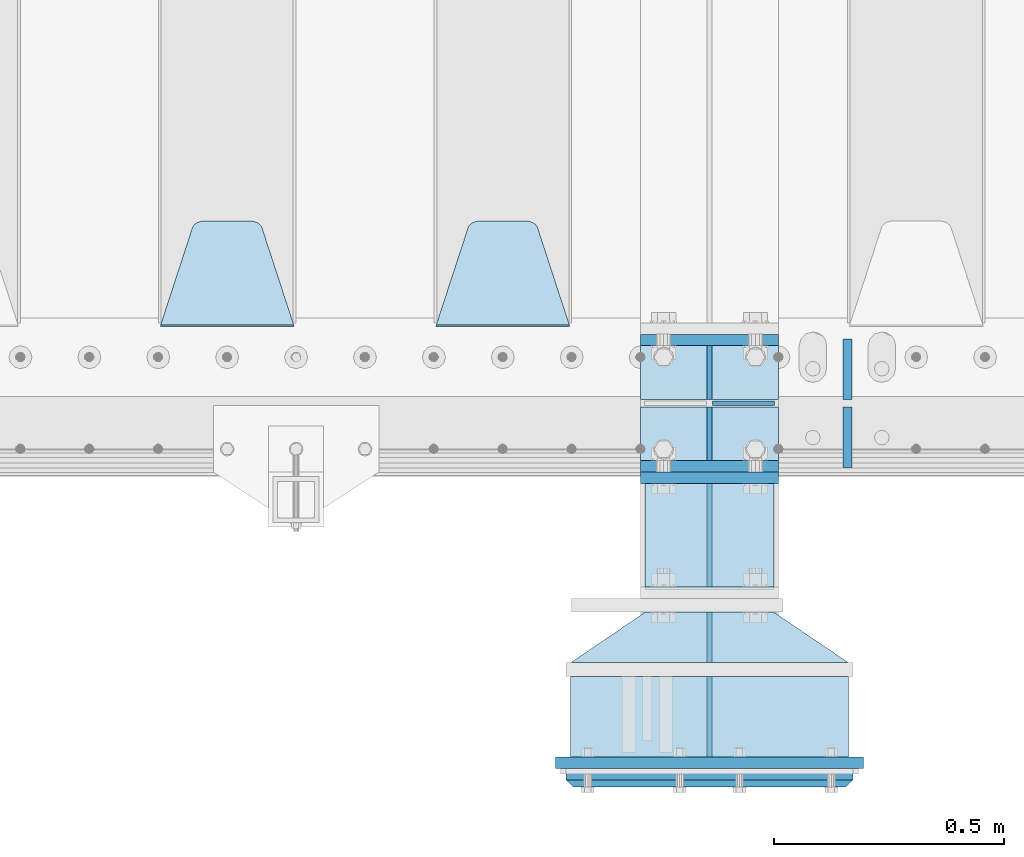
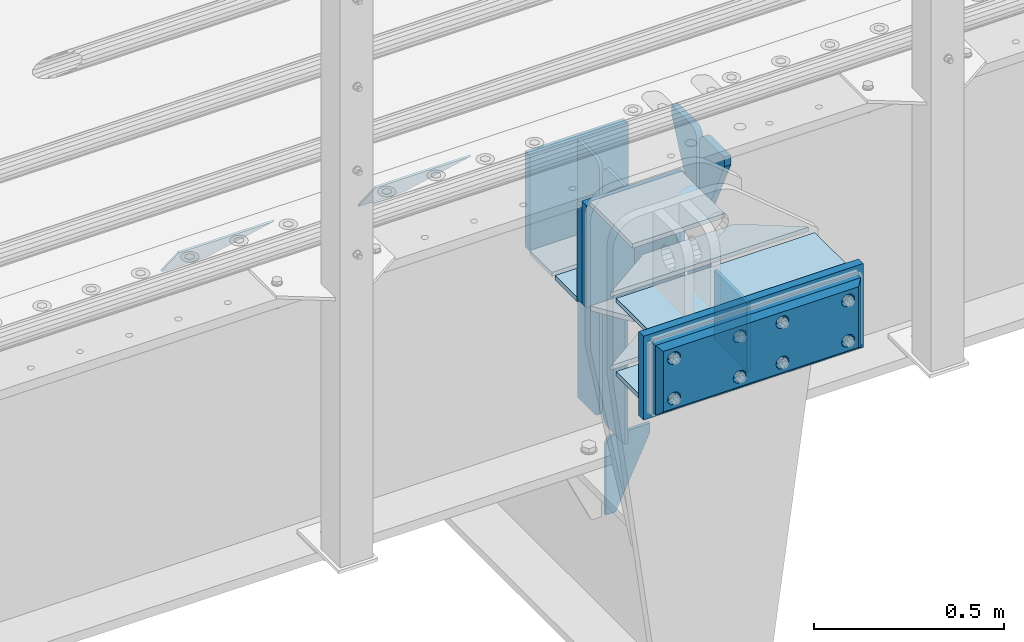
# One storey, part 211 of 257: 25 plates.
"""IFC2X3 building model written with IfcOpenShell, lengths in millimetres."""

import ifcopenshell
import ifcopenshell.guid

model = None  # the IFC model being written
_history = None  # IfcOwnerHistory: only IFC2X3 demands one
_inside = {}  # id of a spatial element -> (the spatial element, [elements in it])
_under = {}  # id of a project, library or spatial element -> (it, [spatial elements below it])
_declared = {}  # id of a project -> (the project, [libraries it declares])
_typed = {}  # id of a type object -> (the type object, [elements of that type])
_made_of = {}  # id of a material, layer set ... -> (it, [elements and type objects made of it])


def new_model(schema):
    """Start an empty IFC model of exactly this schema.

    Asked for "IFC4X3", IfcOpenShell would pick the latest addendum, in which some entities
    have other attributes; the version numbers below select the first issue.
    IFC2X3 requires an IfcOwnerHistory on every rooted entity: one is made here for all.
    """
    global model, _history
    if schema == "IFC4X3":
        model = ifcopenshell.file(schema_version=(4, 3, 0, 0))
    else:
        model = ifcopenshell.file(schema=schema)
    _inside.clear()
    _under.clear()
    _declared.clear()
    _typed.clear()
    _made_of.clear()
    _history = None
    if model.schema == "IFC2X3":
        org = make("IfcOrganization", Name="unknown")
        user = make(
            "IfcPersonAndOrganization",
            ThePerson=make("IfcPerson", FamilyName="unknown"),
            TheOrganization=org,
        )
        app = make(
            "IfcApplication",
            ApplicationDeveloper=org,
            Version="unknown",
            ApplicationFullName="unknown",
            ApplicationIdentifier="unknown",
        )
        _history = make(
            "IfcOwnerHistory",
            OwningUser=user,
            OwningApplication=app,
            ChangeAction="ADDED",
            CreationDate=0,
        )
    return model


def make(cls, **values):
    """One entity of the class cls with the attributes given. An attribute that is None is left unset."""
    return model.create_entity(
        cls, **{name: value for name, value in values.items() if value is not None}
    )


def rooted(cls, **values):
    """An entity with a GlobalId (a new one), such as an element, a storey or a relation."""
    return make(cls, GlobalId=ifcopenshell.guid.new(), OwnerHistory=_history, **values)


def si_unit(unit_type, name, prefix=None):
    """IfcSIUnit, for example si_unit("LENGTHUNIT", "METRE", prefix="MILLI")."""
    return make("IfcSIUnit", UnitType=unit_type, Prefix=prefix, Name=name)


def assignment(units):
    """IfcUnitAssignment: the units of a project."""
    return None if units is None else make("IfcUnitAssignment", Units=units)


def point(xyz):
    """IfcCartesianPoint."""
    return None if xyz is None else make("IfcCartesianPoint", Coordinates=xyz)


def direction(xyz):
    """IfcDirection."""
    return None if xyz is None else make("IfcDirection", DirectionRatios=xyz)


def frame(location, z_axis=None, x_axis=None):
    """IfcAxis2Placement3D, a coordinate frame: its origin and axes. An axis left out is left unset."""
    return make(
        "IfcAxis2Placement3D",
        Location=point(location),
        Axis=direction(z_axis),
        RefDirection=direction(x_axis),
    )


def origin_with_axes():
    """The frame at (0, 0, 0) with the z axis (0, 0, 1) and the x axis (1, 0, 0) written out."""
    return frame((0.0, 0.0, 0.0), z_axis=(0.0, 0.0, 1.0), x_axis=(1.0, 0.0, 0.0))


def place(relative_to, where):
    """IfcLocalPlacement: puts the frame where relative to a parent placement (None: the world)."""
    return make(
        "IfcLocalPlacement", PlacementRelTo=relative_to, RelativePlacement=where
    )


def context(
    kind, dimensions, precision=None, world=None, true_north=None, identifier=None
):
    """IfcGeometricRepresentationContext, for example the 3D "Model" context."""
    return make(
        "IfcGeometricRepresentationContext",
        ContextIdentifier=identifier,
        ContextType=kind,
        CoordinateSpaceDimension=dimensions,
        Precision=precision,
        WorldCoordinateSystem=world,
        TrueNorth=true_north,
    )


def subcontext(parent, identifier, kind, view, scale=None):
    """IfcGeometricRepresentationSubContext, for example "Body" below "Model"."""
    return make(
        "IfcGeometricRepresentationSubContext",
        ContextIdentifier=identifier,
        ContextType=kind,
        ParentContext=parent,
        TargetScale=scale,
        TargetView=view,
    )


def project(units=None, contexts=None):
    """IfcProject with its units and contexts."""
    return rooted(
        "IfcProject",
        Name="project",
        RepresentationContexts=contexts,
        UnitsInContext=assignment(units),
    )


def spatial(cls, under=None, at=None, **own):
    """A site, building, storey or space (cls), placed at a placement, below another one or the project."""
    s = rooted(cls, ObjectPlacement=at, **own)
    if under is not None:
        _under.setdefault(under.id(), (under, []))[1].append(s)
    return s


def faces_of(points, faces, orient=None, outer=None):
    """IfcFace entities. A face is a list of loops; a loop is a list of indices into points, from 0.

    orient and outer hold one flag for each loop. By default every Orientation is true, the
    first loop of a face is its IfcFaceOuterBound and the others are IfcFaceBound.
    """
    made = []
    for i, loops in enumerate(faces):
        bounds = []
        for j, loop in enumerate(loops):
            is_outer = j == 0 if outer is None else outer[i][j]
            bounds.append(
                make(
                    "IfcFaceOuterBound" if is_outer else "IfcFaceBound",
                    Bound=make("IfcPolyLoop", Polygon=[points[k] for k in loop]),
                    Orientation=True if orient is None else orient[i][j],
                )
            )
        made.append(make("IfcFace", Bounds=bounds))
    return made


def faceted_brep(points, faces, orient=None, outer=None, voids=None):
    """IfcFacetedBrep: a solid bounded by flat faces; with voids (closed shells), ...WithVoids."""
    shared = [point(p) for p in points]
    hull = make("IfcClosedShell", CfsFaces=faces_of(shared, faces, orient, outer))
    if voids is None:
        return make("IfcFacetedBrep", Outer=hull)
    return make(
        "IfcFacetedBrepWithVoids",
        Outer=hull,
        Voids=[
            make(cls, CfsFaces=faces_of(shared, fs, o, b)) for cls, fs, o, b in voids
        ],
    )


def shape(context_of_items, identifier, shape_type, items):
    """IfcShapeRepresentation: the items that make up one representation, for example the "Body"."""
    return make(
        "IfcShapeRepresentation",
        ContextOfItems=context_of_items,
        RepresentationIdentifier=identifier,
        RepresentationType=shape_type,
        Items=items,
    )


def material(Name=None, Category=None):
    """IfcMaterial."""
    return make("IfcMaterial", Name=Name, Category=Category)


def made_of(thing, what):
    """Note that an element or type object is made of a material, layer set ...; save() writes the relation."""
    if what is not None:
        _made_of.setdefault(what.id(), (what, []))[1].append(thing)
    return thing


def type_object(cls, material=None, **own):
    """A type object (cls), such as IfcWallType, which elements share."""
    return made_of(rooted(cls, **own), material)


def element(
    cls,
    number,
    at=None,
    inside=None,
    cuts=None,
    type_object=None,
    material=None,
    context=None,
    identifier="Body",
    shape_type=None,
    held_by="IfcProductDefinitionShape",
    body=None,
    shapes=None,
    **own,
):
    """One element of the class cls, such as IfcWall. Its Tag is "e" and its number.

    at: its placement. inside: the storey or other place that contains it. cuts: it is an
    opening in that element (IfcRelVoidsElement). A single representation is given by context,
    identifier, shape_type and body (its items); several are given by shapes. held_by: the class
    of the entity that holds the representations. save() writes the other relations.
    """
    e = rooted(cls, Tag="e%d" % number, ObjectPlacement=at, **own)
    if body is not None:
        shapes = [shape(context, identifier, shape_type, body)]
    if shapes is not None:
        e.Representation = make(held_by, Representations=shapes)
    if inside is not None:
        _inside.setdefault(inside.id(), (inside, []))[1].append(e)
    if cuts is not None:
        rooted(
            "IfcRelVoidsElement", RelatingBuildingElement=cuts, RelatedOpeningElement=e
        )
    if type_object is not None:
        _typed.setdefault(type_object.id(), (type_object, []))[1].append(e)
    return made_of(e, material)


def aggregate(whole, parts):
    """IfcRelAggregates: a whole, such as a stair, and the parts it consists of."""
    return rooted("IfcRelAggregates", RelatingObject=whole, RelatedObjects=parts)


def save(model, path):
    """Write the relations noted so far, then the file.

    IfcRelAggregates (storeys below a building ...), IfcRelContainedInSpatialStructure (elements
    in a storey), IfcRelDefinesByType, IfcRelAssociatesMaterial and IfcRelDeclares: one each for
    every whole, place, type object, material and project.
    """
    for whole, parts in _under.values():
        aggregate(whole, parts)
    for where, things in _inside.values():
        rooted(
            "IfcRelContainedInSpatialStructure",
            RelatedElements=things,
            RelatingStructure=where,
        )
    for kind, things in _typed.values():
        rooted("IfcRelDefinesByType", RelatedObjects=things, RelatingType=kind)
    for what, things in _made_of.values():
        rooted("IfcRelAssociatesMaterial", RelatedObjects=things, RelatingMaterial=what)
    for by, libraries in _declared.values():
        rooted("IfcRelDeclares", RelatingContext=by, RelatedDefinitions=libraries)
    model.write(path)


model = new_model("IFC2X3")

# Units and contexts
model_context = context("Model", 3, precision=1e-05, world=origin_with_axes())
body_context = subcontext(model_context, "Body", "Model", "MODEL_VIEW")
ifc_project = project(units=[si_unit("LENGTHUNIT", "METRE", prefix="MILLI"), si_unit("AREAUNIT", "SQUARE_METRE"), si_unit("VOLUMEUNIT", "CUBIC_METRE"), si_unit("MASSUNIT", "GRAM", prefix="KILO"), si_unit("TIMEUNIT", "SECOND"), si_unit("PLANEANGLEUNIT", "RADIAN"), si_unit("SOLIDANGLEUNIT", "STERADIAN"), si_unit("THERMODYNAMICTEMPERATUREUNIT", "DEGREE_CELSIUS"), si_unit("LUMINOUSINTENSITYUNIT", "LUMEN")], contexts=[model_context])

# Site, building, storey
site_placement = place(None, origin_with_axes())
site = spatial("IfcSite", under=ifc_project, at=site_placement, CompositionType="ELEMENT")
building_placement = place(site_placement, origin_with_axes())
building = spatial("IfcBuilding", under=site, at=building_placement, Name="Standard", CompositionType="ELEMENT")
storey_placement = place(building_placement, origin_with_axes())
storey = spatial("IfcBuildingStorey", under=building, at=storey_placement, Name="Undefined", CompositionType="ELEMENT", Elevation=0.0)

# Plates
ifc_material_1 = material(Name="STEEL/S355N")
plate_type_1 = type_object("IfcPlateType", PredefinedType="NOTDEFINED")
plate_1_placement = place(storey_placement, frame((54550.0, -162.499999995798, -340.000019536858), z_axis=(0.0, 0.0, 1.0), x_axis=(1.0, 0.0, 0.0)))
element("IfcPlate", 1, at=plate_1_placement, inside=storey, type_object=plate_type_1, material=ifc_material_1, context=body_context, shape_type="Brep", body=[
    faceted_brep([(0.0, -12.5, 0.0), (0.0, -12.5, 330.0), (0.0, 12.5, 330.0), (0.0, 12.5, 0.0), (300.0, -12.5, 330.0), (300.0, 12.5, 330.0), (300.0, -12.5, 0.0), (300.0, 12.5, 0.0)], [[[0, 1, 2, 3]], [[1, 4, 5, 2]], [[4, 6, 7, 5]], [[6, 0, 3, 7]], [[5, 7, 3, 2]], [[6, 4, 1, 0]]]),
])
for number, where, z_axis, x_axis in (
    (2, (54550.0, 137.5, -340.0), (0.0, 0.0, 1.0), (1.0, 0.0, 0.0)),
    (3, (54550.0, -137.5, -340.0), (0.0, 0.0, 1.0), (1.0, 0.0, 0.0)),
):
    element("IfcPlate", number, at=place(storey_placement, frame(where, z_axis=z_axis, x_axis=x_axis)), inside=storey, type_object=plate_type_1, material=ifc_material_1, context=body_context, shape_type="Brep", body=[
        faceted_brep([(0.0, -12.5, 0.0), (0.0, -12.5, 310.0), (0.0, 12.5, 310.0), (0.0, 12.5, 0.0), (300.0, -12.5, 310.0), (300.0, 12.5, 310.0), (300.0, -12.5, 0.0), (300.0, 12.5, 0.0)], [[[0, 1, 2, 3]], [[1, 4, 5, 2]], [[4, 6, 7, 5]], [[6, 0, 3, 7]], [[5, 7, 3, 2]], [[6, 4, 1, 0]]]),
    ])
plate_type_2 = type_object("IfcPlateType", PredefinedType="NOTDEFINED")
for number, where, z_axis, x_axis in (
    (4, (54550.0, -8.0, -343.0), (0.0, -1.0, 0.0), (1.0, 0.0, 0.0)),
    (5, (54550.0, 8.0, -343.0), (0.0, 1.0, 0.0), (1.0, 0.0, 0.0)),
):
    element("IfcPlate", number, at=place(storey_placement, frame(where, z_axis=z_axis, x_axis=x_axis)), inside=storey, type_object=plate_type_2, material=ifc_material_1, context=body_context, shape_type="Brep", body=[
        faceted_brep([(0.0, -7.0, 0.0), (0.0, -7.0, 117.0), (0.0, 7.0, 117.0), (0.0, 7.0, 0.0), (300.0, -7.0, 117.0), (300.0, 7.0, 117.0), (300.0, -7.0, 0.0), (300.0, 7.0, 0.0)], [[[0, 1, 2, 3]], [[1, 4, 5, 2]], [[4, 6, 7, 5]], [[6, 0, 3, 7]], [[5, 7, 3, 2]], [[6, 4, 1, 0]]]),
    ])
plate_type_3 = type_object("IfcPlateType", PredefinedType="NOTDEFINED")
for number, where, z_axis, x_axis in (
    (6, (54700.0, -8.0, -350.0), (0.0, 0.0, -1.0), (0.0, -1.0, 0.0)),
    (7, (54700.0, 8.0, -350.0), (0.0, 0.0, -1.0), (0.0, 1.0, 0.0)),
):
    element("IfcPlate", number, at=place(storey_placement, frame(where, z_axis=z_axis, x_axis=x_axis)), inside=storey, type_object=plate_type_3, material=ifc_material_1, context=body_context, shape_type="Brep", body=[
        faceted_brep([(0.0, -5.0, 0.0), (0.0, -5.0, 480.0), (0.0, 5.0, 480.0), (0.0, 5.0, 0.0), (0.455767409633609, -5.0, 485.209445330008), (0.455767409633609, 5.0, 485.209445330008), (1.80922137642256, -5.0, 490.26060429977), (1.80922137642256, 5.0, 490.26060429977), (4.01923788646673, -5.0, 495.0), (4.01923788646673, 5.0, 495.0), (7.01866670643085, -5.0, 499.283628290596), (7.01866670643085, 5.0, 499.283628290596), (10.716371709404, -5.0, 502.981333293569), (10.716371709404, 5.0, 502.981333293569), (15.0, -5.0, 505.980762113533), (15.0, 5.0, 505.980762113533), (19.73939570023, -5.0, 508.190778623577), (19.73939570023, 5.0, 508.190778623577), (24.7905546699922, -5.0, 509.544232590366), (24.7905546699922, 5.0, 509.544232590366), (30.0, -5.0, 510.0), (30.0, 5.0, 510.0), (117.0, -5.0, 510.0), (117.0, 5.0, 510.0), (117.0, -5.0, 0.0), (117.0, 5.0, 0.0)], [[[0, 1, 2, 3]], [[1, 4, 5, 2]], [[4, 6, 7, 5]], [[6, 8, 9, 7]], [[8, 10, 11, 9]], [[10, 12, 13, 11]], [[12, 14, 15, 13]], [[14, 16, 17, 15]], [[16, 18, 19, 17]], [[18, 20, 21, 19]], [[20, 22, 23, 21]], [[22, 24, 25, 23]], [[24, 0, 3, 25]], [[5, 7, 9, 11, 13, 15, 17, 19, 21, 23, 25, 3, 2]], [[24, 22, 20, 18, 16, 14, 12, 10, 8, 6, 4, 1, 0]]]),
    ])
for number, where, z_axis, x_axis in (
    (8, (54700.0, 8.0, -30.0), (0.0, 0.0, -1.0), (0.0, 1.0, 0.0)),
    (9, (54700.0, -8.0, -30.0), (0.0, 0.0, -1.0), (0.0, -1.0, 0.0)),
):
    element("IfcPlate", number, at=place(storey_placement, frame(where, z_axis=z_axis, x_axis=x_axis)), inside=storey, type_object=plate_type_3, material=ifc_material_1, context=body_context, shape_type="Brep", body=[
        faceted_brep([(0.0, -5.0, 30.0), (0.0, -5.0, 306.0), (0.0, 5.0, 306.0), (0.0, 5.0, 30.0), (117.0, -5.0, 306.0), (117.0, 5.0, 306.0), (117.0, -5.0, 0.0), (117.0, 5.0, 0.0), (30.0, -5.0, 0.0), (30.0, 5.0, 0.0), (24.7905546699922, -5.0, 0.455767409633758), (24.7905546699922, 5.0, 0.455767409633758), (19.7393957002296, -5.0, 1.80922137642275), (19.7393957002296, 5.0, 1.80922137642275), (15.0, -5.0, 4.01923788646684), (15.0, 5.0, 4.01923788646684), (10.7163717094036, -5.0, 7.01866670643066), (10.7163717094036, 5.0, 7.01866670643066), (7.01866670643085, -5.0, 10.7163717094038), (7.01866670643085, 5.0, 10.7163717094038), (4.01923788646673, -5.0, 15.0), (4.01923788646673, 5.0, 15.0), (1.80922137642301, -5.0, 19.7393957002299), (1.80922137642301, 5.0, 19.7393957002299), (0.455767409634063, -5.0, 24.7905546699921), (0.455767409634063, 5.0, 24.7905546699921)], [[[0, 1, 2, 3]], [[1, 4, 5, 2]], [[4, 6, 7, 5]], [[6, 8, 9, 7]], [[8, 10, 11, 9]], [[10, 12, 13, 11]], [[12, 14, 15, 13]], [[14, 16, 17, 15]], [[16, 18, 19, 17]], [[18, 20, 21, 19]], [[20, 22, 23, 21]], [[22, 24, 25, 23]], [[24, 0, 3, 25]], [[5, 7, 9, 11, 13, 15, 17, 19, 21, 23, 25, 3, 2]], [[24, 22, 20, 18, 16, 14, 12, 10, 8, 6, 4, 1, 0]]]),
    ])
plate_type_4 = type_object("IfcPlateType", PredefinedType="NOTDEFINED")
plate_2_placement = place(storey_placement, frame((54706.5, 4.20186552219093e-09, -915.000019536857), z_axis=(0.0, 0.0, -1.0), x_axis=(1.0, 0.0, 0.0)))
element("IfcPlate", 10, at=plate_2_placement, inside=storey, type_object=plate_type_4, material=ifc_material_1, context=body_context, shape_type="Brep", body=[
    faceted_brep([(0.0, -5.0, 27.0), (0.0, -5.0, 250.0), (0.0, 5.0, 250.0), (0.0, 5.0, 27.0), (30.0, -5.0, 250.0), (30.0, 5.0, 250.0), (135.0, -5.0, 30.0), (135.0, 5.0, 30.0), (135.0, -5.0, 0.0), (135.0, 5.0, 0.0), (27.0, -5.0, 0.0), (27.0, 5.0, 0.0), (22.311499202995, -5.0, 0.410190668670339), (22.311499202995, 5.0, 0.410190668670339), (17.7654561302043, -5.0, 1.62829923878053), (17.7654561302043, 5.0, 1.62829923878053), (13.5, -5.0, 3.6173140978201), (13.5, 5.0, 3.6173140978201), (9.64473453846585, -5.0, 6.31680003578754), (9.64473453846585, 5.0, 6.31680003578754), (6.31680003579095, -5.0, 9.64473453846347), (6.31680003579095, 5.0, 9.64473453846347), (3.61731409782078, -5.0, 13.5), (3.61731409782078, 5.0, 13.5), (1.62829923877871, -5.0, 17.765456130207), (1.62829923877871, 5.0, 17.765456130207), (0.410190668670111, -5.0, 22.3114992029929), (0.410190668670111, 5.0, 22.3114992029929)], [[[0, 1, 2, 3]], [[1, 4, 5, 2]], [[4, 6, 7, 5]], [[6, 8, 9, 7]], [[8, 10, 11, 9]], [[10, 12, 13, 11]], [[12, 14, 15, 13]], [[14, 16, 17, 15]], [[16, 18, 19, 17]], [[18, 20, 21, 19]], [[20, 22, 23, 21]], [[22, 24, 25, 23]], [[24, 26, 27, 25]], [[26, 0, 3, 27]], [[5, 7, 9, 11, 13, 15, 17, 19, 21, 23, 25, 27, 3, 2]], [[26, 24, 22, 20, 18, 16, 14, 12, 10, 8, 6, 4, 1, 0]]]),
])
plate_type_5 = type_object("IfcPlateType", PredefinedType="NOTDEFINED")
plate_3_placement = place(storey_placement, frame((54395.0, 168.232233047035, -1.76776695296758), z_axis=(0.0, 0.707106781186547, -0.707106781186548), x_axis=(-1.0, 0.0, 0.0)))
element("IfcPlate", 11, at=plate_3_placement, inside=storey, type_object=plate_type_5, material=ifc_material_1, context=body_context, shape_type="Brep", body=[
    faceted_brep([(0.0, -2.5, 0.0), (69.345504679477, -2.50000000000091, 300.17173142483), (69.345504679477, 2.5, 300.171731424831), (0.0, 2.5, 0.0), (70.927406119954, -2.50000000000091, 304.8974424154), (70.927406119954, 2.5, 304.8974424154), (73.3818627772271, -2.50000000000091, 309.234538108527), (73.3818627772271, 2.49999999999909, 309.234538108527), (76.6187032999587, -2.5, 313.023683126103), (76.6187032999587, 2.5, 313.023683126103), (80.5190132705029, -2.5, 316.125672595372), (80.5190132705029, 2.5, 316.125672595371), (84.9395038596849, -2.5, 318.426546230476), (84.9395038596849, 2.5, 318.426546230477), (89.7177759439219, -2.5, 319.841774983275), (89.7177759439219, 2.5, 319.841774983275), (94.6782862926484, -2.5, 320.319366455079), (94.6782862926484, 2.5, 320.319366455079), (195.321713707352, -2.5, 320.319366455079), (195.321713707352, 2.5, 320.319366455079), (200.282224056078, -2.5, 319.841774983275), (200.282224056078, 2.49999999999909, 319.841774983275), (205.060496140315, -2.5, 318.426546230476), (205.060496140315, 2.49999999999909, 318.426546230475), (209.480986729497, -2.5, 316.125672595371), (209.480986729497, 2.5, 316.125672595371), (213.381296700041, -2.50000000000091, 313.023683126102), (213.381296700041, 2.5, 313.023683126103), (216.618137222766, -2.50000000000091, 309.234538108527), (216.618137222766, 2.5, 309.234538108527), (219.072593880039, -2.5, 304.897442415399), (219.072593880039, 2.5, 304.897442415399), (220.654495320523, -2.50000000000091, 300.17173142483), (220.654495320523, 2.5, 300.171731424831), (290.0, -2.50000000000091, 0.0), (290.0, 2.5, 9.09494701772928e-13)], [[[0, 1, 2, 3]], [[1, 4, 5, 2]], [[4, 6, 7, 5]], [[6, 8, 9, 7]], [[8, 10, 11, 9]], [[10, 12, 13, 11]], [[12, 14, 15, 13]], [[14, 16, 17, 15]], [[16, 18, 19, 17]], [[18, 20, 21, 19]], [[20, 22, 23, 21]], [[22, 24, 25, 23]], [[24, 26, 27, 25]], [[26, 28, 29, 27]], [[28, 30, 31, 29]], [[30, 32, 33, 31]], [[32, 34, 35, 33]], [[34, 0, 3, 35]], [[5, 7, 9, 11, 13, 15, 17, 19, 21, 23, 25, 27, 29, 31, 33, 35, 3, 2]], [[34, 32, 30, 28, 26, 24, 22, 20, 18, 16, 14, 12, 10, 8, 6, 4, 1, 0]]]),
])
plate_4_placement = place(storey_placement, frame((53795.0, 168.232233047035, -1.76776695296758), z_axis=(0.0, 0.707106781186547, -0.707106781186548), x_axis=(-1.0, 0.0, 0.0)))
element("IfcPlate", 12, at=plate_4_placement, inside=storey, type_object=plate_type_5, material=ifc_material_1, context=body_context, shape_type="Brep", body=[
    faceted_brep([(0.0, -2.5, 0.0), (69.345504679477, -2.50000000000091, 300.17173142483), (69.345504679477, 2.5, 300.171731424831), (0.0, 2.5, 0.0), (70.927406119954, -2.50000000000091, 304.8974424154), (70.927406119954, 2.5, 304.8974424154), (73.3818627772271, -2.50000000000091, 309.234538108527), (73.3818627772271, 2.49999999999909, 309.234538108527), (76.6187032999587, -2.5, 313.023683126103), (76.6187032999587, 2.5, 313.023683126103), (80.5190132705029, -2.5, 316.125672595372), (80.5190132705029, 2.5, 316.125672595371), (84.9395038596849, -2.5, 318.426546230476), (84.9395038596849, 2.5, 318.426546230477), (89.7177759439219, -2.5, 319.841774983275), (89.7177759439219, 2.5, 319.841774983275), (94.6782862926484, -2.5, 320.319366455079), (94.6782862926484, 2.5, 320.319366455079), (195.321713707352, -2.5, 320.319366455079), (195.321713707352, 2.5, 320.319366455079), (200.282224056078, -2.5, 319.841774983275), (200.282224056078, 2.49999999999909, 319.841774983275), (205.060496140315, -2.5, 318.426546230476), (205.060496140315, 2.49999999999909, 318.426546230475), (209.480986729497, -2.5, 316.125672595371), (209.480986729497, 2.5, 316.125672595371), (213.381296700041, -2.50000000000091, 313.023683126102), (213.381296700041, 2.5, 313.023683126103), (216.618137222766, -2.50000000000091, 309.234538108527), (216.618137222766, 2.5, 309.234538108527), (219.072593880039, -2.5, 304.897442415399), (219.072593880039, 2.5, 304.897442415399), (220.654495320523, -2.50000000000091, 300.17173142483), (220.654495320523, 2.5, 300.171731424831), (290.0, -2.50000000000091, 0.0), (290.0, 2.5, 9.09494701772928e-13)], [[[0, 1, 2, 3]], [[1, 4, 5, 2]], [[4, 6, 7, 5]], [[6, 8, 9, 7]], [[8, 10, 11, 9]], [[10, 12, 13, 11]], [[12, 14, 15, 13]], [[14, 16, 17, 15]], [[16, 18, 19, 17]], [[18, 20, 21, 19]], [[20, 22, 23, 21]], [[22, 24, 25, 23]], [[24, 26, 27, 25]], [[26, 28, 29, 27]], [[28, 30, 31, 29]], [[30, 32, 33, 31]], [[32, 34, 35, 33]], [[34, 0, 3, 35]], [[5, 7, 9, 11, 13, 15, 17, 19, 21, 23, 25, 27, 29, 31, 33, 35, 3, 2]], [[34, 32, 30, 28, 26, 24, 22, 20, 18, 16, 14, 12, 10, 8, 6, 4, 1, 0]]]),
])
plate_type_6 = type_object("IfcPlateType", PredefinedType="NOTDEFINED")
for number, where, z_axis, x_axis in (
    (13, (55000.0, -140.0, -30.0), (0.0, 0.0, -1.0), (0.0, 1.0, 0.0)),
    (14, (55000.0, 140.0, -30.0), (0.0, 0.0, -1.0), (0.0, -1.0, 0.0)),
):
    element("IfcPlate", number, at=place(storey_placement, frame(where, z_axis=z_axis, x_axis=x_axis)), inside=storey, type_object=plate_type_6, material=ifc_material_1, context=body_context, shape_type="Brep", body=[
        faceted_brep([(0.0, -10.0, 0.0), (0.0, -10.0, 30.0), (0.0, 10.0, 30.0), (0.0, 10.0, 0.0), (102.0, -10.0, 250.0), (102.0, 10.0, 250.0), (132.0, -10.0, 250.0), (132.0, 10.0, 250.0), (132.0, -10.0, 30.0), (132.0, 10.0, 30.0), (131.544232590366, -10.0, 24.790554669992), (131.544232590366, 10.0, 24.790554669992), (130.190778623577, -10.0, 19.7393957002299), (130.190778623577, 10.0, 19.7393957002299), (127.980762113533, -10.0, 15.0), (127.980762113533, 10.0, 15.0), (124.981333293569, -10.0, 10.7163717094038), (124.981333293569, 10.0, 10.7163717094038), (121.283628290596, -10.0, 7.01866670643062), (121.283628290596, 10.0, 7.01866670643062), (117.0, -10.0, 4.01923788646684), (117.0, 10.0, 4.01923788646684), (112.26060429977, -10.0, 1.80922137642278), (112.26060429977, 10.0, 1.80922137642278), (107.209445330008, -10.0, 0.455767409633722), (107.209445330008, 10.0, 0.455767409633722), (102.0, -10.0, 0.0), (102.0, 10.0, 0.0)], [[[0, 1, 2, 3]], [[1, 4, 5, 2]], [[4, 6, 7, 5]], [[6, 8, 9, 7]], [[8, 10, 11, 9]], [[10, 12, 13, 11]], [[12, 14, 15, 13]], [[14, 16, 17, 15]], [[16, 18, 19, 17]], [[18, 20, 21, 19]], [[20, 22, 23, 21]], [[22, 24, 25, 23]], [[24, 26, 27, 25]], [[26, 0, 3, 27]], [[5, 7, 9, 11, 13, 15, 17, 19, 21, 23, 25, 27, 3, 2]], [[26, 24, 22, 20, 18, 16, 14, 12, 10, 8, 6, 4, 1, 0]]]),
    ])
plate_type_7 = type_object("IfcPlateType", PredefinedType="NOTDEFINED")
plate_5_placement = place(storey_placement, frame((54700.0, -564.999999995798, -14.0000195368585), z_axis=(0.0, 0.0, -1.0), x_axis=(0.0, 1.0, 0.0)))
element("IfcPlate", 15, at=plate_5_placement, inside=storey, type_object=plate_type_7, material=ifc_material_1, context=body_context, shape_type="Brep", body=[
    faceted_brep([(0.0, -5.0, 0.0), (0.0, -5.0, 222.0), (0.0, 5.0, 222.0), (0.0, 5.0, 0.0), (110.0, -5.0, 222.0), (110.0, 5.0, 222.0), (110.0, -5.0, 0.0), (110.0, 5.0, 0.0)], [[[0, 1, 2, 3]], [[1, 4, 5, 2]], [[4, 6, 7, 5]], [[6, 0, 3, 7]], [[5, 7, 3, 2]], [[6, 4, 1, 0]]]),
])
plate_type_8 = type_object("IfcPlateType", PredefinedType="NOTDEFINED")
for number, where, z_axis, x_axis in (
    (16, (55002.5, -564.999999995798, -7.00001953685853), (-0.560566412034006, -0.828109472050236, 0.0), (-0.828109472050236, 0.560566412034006, 0.0)),
    (17, (55002.5, -564.999999995798, -243.000019536859), (-0.560566412034006, -0.828109472050236, 0.0), (-0.828109472050236, 0.560566412034006, 0.0)),
):
    element("IfcPlate", number, at=place(storey_placement, frame(where, z_axis=z_axis, x_axis=x_axis)), inside=storey, type_object=plate_type_8, material=ifc_material_1, context=body_context, shape_type="Brep", body=[
        faceted_brep([(0.0, -7.0, 0.0), (501.00622558593, -7.0, 339.142669677727), (501.00622558593, 7.0, 339.142669677727), (0.0, 7.0, 0.0), (428.100738525376, -7.0, 156.958602905266), (428.100738525376, 7.0, 156.958602905266), (196.230087280266, -7.0, -4.36557456851006e-11), (196.230087280266, 7.0, -4.36557456851006e-11)], [[[0, 1, 2, 3]], [[1, 4, 5, 2]], [[4, 6, 7, 5]], [[6, 0, 3, 7]], [[5, 7, 3, 2]], [[6, 4, 1, 0]]]),
    ])
ifc_material_2 = material()
plate_type_9 = type_object("IfcPlateType", PredefinedType="NOTDEFINED")
for number, where, z_axis, x_axis in (
    (18, (55002.5, -594.999999995798, -243.000019536859), (0.0, -1.0, 0.0), (-1.0, 0.0, 0.0)),
    (19, (55002.5, -594.999999995798, -7.00001953685853), (0.0, -1.0, 0.0), (-1.0, 0.0, 0.0)),
):
    element("IfcPlate", number, at=place(storey_placement, frame(where, z_axis=z_axis, x_axis=x_axis)), inside=storey, type_object=plate_type_9, material=ifc_material_2, context=body_context, shape_type="Brep", body=[
        faceted_brep([(0.0, -7.0, 0.0), (0.0, -7.0, 175.0), (0.0, 7.0, 175.0), (0.0, 7.0, 0.0), (605.0, -7.0, 175.0), (605.0, 7.0, 175.0), (605.0, -7.0, 0.0), (605.0, 7.0, 0.0)], [[[0, 1, 2, 3]], [[1, 4, 5, 2]], [[4, 6, 7, 5]], [[6, 0, 3, 7]], [[5, 7, 3, 2]], [[6, 4, 1, 0]]]),
    ])
plate_type_10 = type_object("IfcPlateType", PredefinedType="NOTDEFINED")
plate_6_placement = place(storey_placement, frame((55035.0, -782.499999995798, 9.99998046314147), z_axis=(0.0, 0.0, -1.0), x_axis=(-1.0, 0.0, 0.0)))
element("IfcPlate", 20, at=plate_6_placement, inside=storey, type_object=plate_type_10, material=ifc_material_1, context=body_context, shape_type="Brep", body=[
    faceted_brep([(0.0, -12.5, 0.0), (0.0, -12.5, 270.0), (0.0, 12.5, 270.0), (0.0, 12.5, 0.0), (670.0, -12.5, 270.0), (670.0, 12.5, 270.0), (670.0, -12.5, 0.0), (670.0, 12.5, 0.0)], [[[0, 1, 2, 3]], [[1, 4, 5, 2]], [[4, 6, 7, 5]], [[6, 0, 3, 7]], [[5, 7, 3, 2]], [[6, 4, 1, 0]]]),
])
plate_type_11 = type_object("IfcPlateType", PredefinedType="NOTDEFINED")
plate_7_placement = place(storey_placement, frame((54700.0, -769.999999995798, -14.0000195368585), z_axis=(0.0, 0.0, -1.0), x_axis=(0.0, 1.0, 0.0)))
element("IfcPlate", 21, at=plate_7_placement, inside=storey, type_object=plate_type_11, material=ifc_material_1, context=body_context, shape_type="Brep", body=[
    faceted_brep([(0.0, -5.0, 0.0), (0.0, -5.0, 222.0), (0.0, 5.0, 222.0), (0.0, 5.0, 0.0), (175.0, -5.0, 222.0), (175.0, 5.0, 222.0), (175.0, -5.0, 0.0), (175.0, 5.0, 0.0)], [[[0, 1, 2, 3]], [[1, 4, 5, 2]], [[4, 6, 7, 5]], [[6, 0, 3, 7]], [[5, 7, 3, 2]], [[6, 4, 1, 0]]]),
])
ifc_material_3 = material()
plate_type_12 = type_object("IfcPlateType", PredefinedType="NOTDEFINED")
plate_8_placement = place(storey_placement, frame((55012.5, -814.999999995798, -12.5000195368585), z_axis=(0.0, 0.0, -1.0), x_axis=(-1.0, 0.0, 0.0)))
element("IfcPlate", 22, at=plate_8_placement, inside=storey, type_object=plate_type_12, material=ifc_material_3, context=body_context, shape_type="Brep", body=[
    faceted_brep([(0.0, -5.0, 0.0), (15.0, -20.0, 15.0), (15.0, -20.0, 210.0), (0.0, -5.0, 225.0), (625.0, -5.0, 225.0), (610.0, -20.0, 210.0), (610.0, -20.0, 15.0), (625.0, -5.0, 0.0), (625.0, 15.0, 0.0), (620.0, 20.0, 5.0), (620.0, 20.0, 220.0), (625.0, 15.0, 225.0), (0.0, 15.0, 225.0), (5.0, 20.0, 220.0), (5.0, 20.0, 5.0), (0.0, 15.0, 0.0), (30.1794919243112, 5.0, 167.499999999998), (37.5, 5.0, 160.179491924309), (47.5, 5.0, 157.499999999998), (57.5, 5.0, 160.179491924309), (64.8205080756888, 5.0, 167.499999999998), (67.5, 5.0, 177.499999999998), (64.8205080756888, 5.0, 187.499999999998), (57.5, 5.0, 194.820508075687), (47.5, 5.0, 197.499999999998), (37.5, 5.0, 194.820508075687), (30.1794919243112, 5.0, 187.499999999998), (27.5, 5.0, 177.499999999998), (37.5, -20.0, 160.179491924309), (30.1794919243112, -20.0, 167.499999999998), (47.5, -20.0, 157.499999999998), (57.5, -20.0, 160.179491924309), (64.8205080756888, -20.0, 167.499999999998), (67.5, -20.0, 177.499999999998), (64.8205080756888, -20.0, 187.499999999998), (57.5, -20.0, 194.820508075687), (47.5, -20.0, 197.499999999998), (37.5, -20.0, 194.820508075687), (30.1794919243112, -20.0, 187.499999999998), (27.5, -20.0, 177.499999999998), (30.1794919243112, 5.0, 37.4999999999982), (37.5, 5.0, 30.1794919243094), (47.5, 5.0, 27.4999999999982), (57.5, 5.0, 30.1794919243094), (64.8205080756888, 5.0, 37.4999999999982), (67.5, 5.0, 47.4999999999982), (64.8205080756888, 5.0, 57.4999999999982), (57.5, 5.0, 64.8205080756869), (47.5, 5.0, 67.4999999999982), (37.5, 5.0, 64.820508075687), (30.1794919243112, 5.0, 57.4999999999982), (27.5, 5.0, 47.4999999999982), (30.1794919243112, -20.0, 37.4999999999982), (27.5, -20.0, 47.4999999999982), (37.5, -20.0, 30.1794919243094), (47.5, -20.0, 27.4999999999982), (57.5, -20.0, 30.1794919243094), (64.8205080756888, -20.0, 37.4999999999982), (67.5, -20.0, 47.4999999999982), (64.8205080756888, -20.0, 57.4999999999982), (57.5, -20.0, 64.8205080756869), (47.5, -20.0, 67.4999999999982), (37.5, -20.0, 64.820508075687), (30.1794919243112, -20.0, 57.4999999999982), (230.179491924311, 5.0, 37.4999999999982), (237.5, 5.0, 30.1794919243094), (247.5, 5.0, 27.4999999999982), (257.5, 5.0, 30.1794919243094), (264.820508075689, 5.0, 37.4999999999982), (267.5, 5.0, 47.4999999999982), (264.820508075689, 5.0, 57.4999999999982), (257.5, 5.0, 64.8205080756869), (247.5, 5.0, 67.4999999999982), (237.5, 5.0, 64.820508075687), (230.179491924311, 5.0, 57.4999999999982), (227.5, 5.0, 47.4999999999982), (230.179491924311, -20.0, 37.4999999999982), (227.5, -20.0, 47.4999999999982), (237.5, -20.0, 30.1794919243094), (247.5, -20.0, 27.4999999999982), (257.5, -20.0, 30.1794919243094), (264.820508075689, -20.0, 37.4999999999982), (267.5, -20.0, 47.4999999999982), (264.820508075689, -20.0, 57.4999999999982), (257.5, -20.0, 64.8205080756869), (247.5, -20.0, 67.4999999999982), (237.5, -20.0, 64.820508075687), (230.179491924311, -20.0, 57.4999999999982), (360.179491924311, 5.0, 37.4999999999982), (367.5, 5.0, 30.1794919243094), (377.5, 5.0, 27.4999999999982), (387.5, 5.0, 30.1794919243094), (394.820508075689, 5.0, 37.4999999999982), (397.5, 5.0, 47.4999999999982), (394.820508075689, 5.0, 57.4999999999982), (387.5, 5.0, 64.8205080756869), (377.5, 5.0, 67.4999999999982), (367.5, 5.0, 64.820508075687), (360.179491924311, 5.0, 57.4999999999982), (357.5, 5.0, 47.4999999999982), (360.179491924311, -20.0, 37.4999999999982), (357.5, -20.0, 47.4999999999982), (367.5, -20.0, 30.1794919243094), (377.5, -20.0, 27.4999999999982), (387.5, -20.0, 30.1794919243094), (394.820508075689, -20.0, 37.4999999999982), (397.5, -20.0, 47.4999999999982), (394.820508075689, -20.0, 57.4999999999982), (387.5, -20.0, 64.8205080756869), (377.5, -20.0, 67.4999999999982), (367.5, -20.0, 64.820508075687), (360.179491924311, -20.0, 57.4999999999982), (560.179491924311, 5.0, 37.4999999999982), (567.5, 5.0, 30.1794919243094), (577.5, 5.0, 27.4999999999982), (587.5, 5.0, 30.1794919243094), (594.820508075689, 5.0, 37.4999999999982), (597.5, 5.0, 47.4999999999982), (594.820508075689, 5.0, 57.4999999999982), (587.5, 5.0, 64.8205080756869), (577.5, 5.0, 67.4999999999982), (567.5, 5.0, 64.820508075687), (560.179491924311, 5.0, 57.4999999999982), (557.5, 5.0, 47.4999999999982), (560.179491924311, -20.0, 37.4999999999982), (557.5, -20.0, 47.4999999999982), (567.5, -20.0, 30.1794919243094), (577.5, -20.0, 27.4999999999982), (587.5, -20.0, 30.1794919243094), (594.820508075689, -20.0, 37.4999999999982), (597.5, -20.0, 47.4999999999982), (594.820508075689, -20.0, 57.4999999999982), (587.5, -20.0, 64.8205080756869), (577.5, -20.0, 67.4999999999982), (567.5, -20.0, 64.820508075687), (560.179491924311, -20.0, 57.4999999999982), (560.179491924311, 5.0, 167.499999999998), (567.5, 5.0, 160.179491924309), (577.5, 5.0, 157.499999999998), (587.5, 5.0, 160.179491924309), (594.820508075689, 5.0, 167.499999999998), (597.5, 5.0, 177.499999999998), (594.820508075689, 5.0, 187.499999999998), (587.5, 5.0, 194.820508075687), (577.5, 5.0, 197.499999999998), (567.5, 5.0, 194.820508075687), (560.179491924311, 5.0, 187.499999999998), (557.5, 5.0, 177.499999999998), (560.179491924311, -20.0, 167.499999999998), (557.5, -20.0, 177.499999999998), (567.5, -20.0, 160.179491924309), (577.5, -20.0, 157.499999999998), (587.5, -20.0, 160.179491924309), (594.820508075689, -20.0, 167.499999999998), (597.5, -20.0, 177.499999999998), (594.820508075689, -20.0, 187.499999999998), (587.5, -20.0, 194.820508075687), (577.5, -20.0, 197.499999999998), (567.5, -20.0, 194.820508075687), (560.179491924311, -20.0, 187.499999999998), (360.179491924311, 5.0, 167.499999999998), (367.5, 5.0, 160.179491924309), (377.5, 5.0, 157.499999999998), (387.5, 5.0, 160.179491924309), (394.820508075689, 5.0, 167.499999999998), (397.5, 5.0, 177.499999999998), (394.820508075689, 5.0, 187.499999999998), (387.5, 5.0, 194.820508075687), (377.5, 5.0, 197.499999999998), (367.5, 5.0, 194.820508075687), (360.179491924311, 5.0, 187.499999999998), (357.5, 5.0, 177.499999999998), (360.179491924311, -20.0, 167.499999999998), (357.5, -20.0, 177.499999999998), (367.5, -20.0, 160.179491924309), (377.5, -20.0, 157.499999999998), (387.5, -20.0, 160.179491924309), (394.820508075689, -20.0, 167.499999999998), (397.5, -20.0, 177.499999999998), (394.820508075689, -20.0, 187.499999999998), (387.5, -20.0, 194.820508075687), (377.5, -20.0, 197.499999999998), (367.5, -20.0, 194.820508075687), (360.179491924311, -20.0, 187.499999999998), (230.179491924311, 5.0, 167.499999999998), (237.5, 5.0, 160.179491924309), (247.5, 5.0, 157.499999999998), (257.5, 5.0, 160.179491924309), (264.820508075689, 5.0, 167.499999999998), (267.5, 5.0, 177.499999999998), (264.820508075689, 5.0, 187.499999999998), (257.5, 5.0, 194.820508075687), (247.5, 5.0, 197.499999999998), (237.5, 5.0, 194.820508075687), (230.179491924311, 5.0, 187.499999999998), (227.5, 5.0, 177.499999999998), (230.179491924311, -20.0, 167.499999999998), (227.5, -20.0, 177.499999999998), (237.5, -20.0, 160.179491924309), (247.5, -20.0, 157.499999999998), (257.5, -20.0, 160.179491924309), (264.820508075689, -20.0, 167.499999999998), (267.5, -20.0, 177.499999999998), (264.820508075689, -20.0, 187.499999999998), (257.5, -20.0, 194.820508075687), (247.5, -20.0, 197.499999999998), (237.5, -20.0, 194.820508075687), (230.179491924311, -20.0, 187.499999999998)], [[[0, 1, 2, 3]], [[4, 5, 6, 7]], [[8, 9, 10, 11]], [[12, 13, 14, 15]], [[15, 14, 9, 8]], [[5, 4, 3, 2]], [[13, 12, 11, 10]], [[7, 6, 1, 0]], [[16, 17, 18, 19, 20, 21, 22, 23, 24, 25, 26, 27]], [[28, 17, 16, 29]], [[30, 18, 17, 28]], [[31, 19, 18, 30]], [[32, 20, 19, 31]], [[33, 21, 20, 32]], [[34, 22, 21, 33]], [[35, 23, 22, 34]], [[36, 24, 23, 35]], [[37, 25, 24, 36]], [[38, 26, 25, 37]], [[39, 27, 26, 38]], [[29, 16, 27, 39]], [[11, 12, 3, 4]], [[8, 11, 4, 7]], [[7, 0, 15, 8]], [[14, 13, 10, 9]], [[12, 15, 0, 3]], [[40, 41, 42, 43, 44, 45, 46, 47, 48, 49, 50, 51]], [[52, 40, 51, 53]], [[54, 41, 40, 52]], [[55, 42, 41, 54]], [[56, 43, 42, 55]], [[57, 44, 43, 56]], [[58, 45, 44, 57]], [[59, 46, 45, 58]], [[60, 47, 46, 59]], [[61, 48, 47, 60]], [[62, 49, 48, 61]], [[63, 50, 49, 62]], [[53, 51, 50, 63]], [[64, 65, 66, 67, 68, 69, 70, 71, 72, 73, 74, 75]], [[76, 64, 75, 77]], [[78, 65, 64, 76]], [[79, 66, 65, 78]], [[80, 67, 66, 79]], [[81, 68, 67, 80]], [[82, 69, 68, 81]], [[83, 70, 69, 82]], [[84, 71, 70, 83]], [[85, 72, 71, 84]], [[86, 73, 72, 85]], [[87, 74, 73, 86]], [[77, 75, 74, 87]], [[88, 89, 90, 91, 92, 93, 94, 95, 96, 97, 98, 99]], [[100, 88, 99, 101]], [[102, 89, 88, 100]], [[103, 90, 89, 102]], [[104, 91, 90, 103]], [[105, 92, 91, 104]], [[106, 93, 92, 105]], [[107, 94, 93, 106]], [[108, 95, 94, 107]], [[109, 96, 95, 108]], [[110, 97, 96, 109]], [[111, 98, 97, 110]], [[101, 99, 98, 111]], [[112, 113, 114, 115, 116, 117, 118, 119, 120, 121, 122, 123]], [[124, 112, 123, 125]], [[126, 113, 112, 124]], [[127, 114, 113, 126]], [[128, 115, 114, 127]], [[129, 116, 115, 128]], [[130, 117, 116, 129]], [[131, 118, 117, 130]], [[132, 119, 118, 131]], [[133, 120, 119, 132]], [[134, 121, 120, 133]], [[135, 122, 121, 134]], [[125, 123, 122, 135]], [[136, 137, 138, 139, 140, 141, 142, 143, 144, 145, 146, 147]], [[148, 136, 147, 149]], [[150, 137, 136, 148]], [[151, 138, 137, 150]], [[152, 139, 138, 151]], [[153, 140, 139, 152]], [[154, 141, 140, 153]], [[155, 142, 141, 154]], [[156, 143, 142, 155]], [[157, 144, 143, 156]], [[158, 145, 144, 157]], [[159, 146, 145, 158]], [[149, 147, 146, 159]], [[160, 161, 162, 163, 164, 165, 166, 167, 168, 169, 170, 171]], [[172, 160, 171, 173]], [[174, 161, 160, 172]], [[175, 162, 161, 174]], [[176, 163, 162, 175]], [[177, 164, 163, 176]], [[178, 165, 164, 177]], [[179, 166, 165, 178]], [[180, 167, 166, 179]], [[181, 168, 167, 180]], [[182, 169, 168, 181]], [[183, 170, 169, 182]], [[173, 171, 170, 183]], [[184, 185, 186, 187, 188, 189, 190, 191, 192, 193, 194, 195]], [[196, 184, 195, 197]], [[198, 185, 184, 196]], [[199, 186, 185, 198]], [[200, 187, 186, 199]], [[201, 188, 187, 200]], [[202, 189, 188, 201]], [[203, 190, 189, 202]], [[204, 191, 190, 203]], [[205, 192, 191, 204]], [[206, 193, 192, 205]], [[207, 194, 193, 206]], [[197, 195, 194, 207]], [[6, 5, 2, 1], [37, 36, 35, 34, 33, 32, 31, 30, 28, 29, 39, 38], [206, 205, 204, 203, 202, 201, 200, 199, 198, 196, 197, 207], [182, 181, 180, 179, 178, 177, 176, 175, 174, 172, 173, 183], [158, 157, 156, 155, 154, 153, 152, 151, 150, 148, 149, 159], [134, 133, 132, 131, 130, 129, 128, 127, 126, 124, 125, 135], [110, 109, 108, 107, 106, 105, 104, 103, 102, 100, 101, 111], [86, 85, 84, 83, 82, 81, 80, 79, 78, 76, 77, 87], [62, 61, 60, 59, 58, 57, 56, 55, 54, 52, 53, 63]]]),
])
plate_type_13 = type_object("IfcPlateType", PredefinedType="NOTDEFINED")
plate_9_placement = place(storey_placement, frame((54700.0, -174.999999995798, -336.000019536858), z_axis=(0.0, -1.0, 0.0), x_axis=(0.0, 0.0, 1.0)))
element("IfcPlate", 23, at=plate_9_placement, inside=storey, type_object=plate_type_13, material=ifc_material_1, context=body_context, shape_type="Brep", body=[
    faceted_brep([(0.0, -5.0, 0.0), (100.0, -5.0, 225.0), (100.0, 5.0, 225.0), (0.0, 5.0, 0.0), (322.0, -5.0, 225.0), (322.0, 5.0, 225.0), (322.0, -5.0, 0.0), (322.0, 5.0, 0.0)], [[[0, 1, 2, 3]], [[1, 4, 5, 2]], [[4, 6, 7, 5]], [[6, 0, 3, 7]], [[5, 7, 3, 2]], [[6, 4, 1, 0]]]),
])
plate_type_14 = type_object("IfcPlateType", PredefinedType="NOTDEFINED")
plate_10_placement = place(storey_placement, frame((54560.0, -174.999999995798, -7.00001953685853), z_axis=(0.0, -1.0, 0.0), x_axis=(1.0, 0.0, 0.0)))
element("IfcPlate", 24, at=plate_10_placement, inside=storey, type_object=plate_type_14, material=ifc_material_1, context=body_context, shape_type="Brep", body=[
    faceted_brep([(0.0, -7.0, 0.0), (0.0, -7.0, 225.0), (0.0, 7.0, 225.0), (0.0, 7.0, 0.0), (280.0, -7.0, 225.0), (280.0, 7.0, 225.0), (280.0, -7.0, 0.0), (280.0, 7.0, 0.0)], [[[0, 1, 2, 3]], [[1, 4, 5, 2]], [[4, 6, 7, 5]], [[6, 0, 3, 7]], [[5, 7, 3, 2]], [[6, 4, 1, 0]]]),
])
plate_type_15 = type_object("IfcPlateType", PredefinedType="NOTDEFINED")
plate_11_placement = place(storey_placement, frame((54560.0, -177.842969258168, -342.3967003772), z_axis=(0.0, -0.913811548702731, 0.406138465867881), x_axis=(1.0, 0.0, 0.0)))
element("IfcPlate", 25, at=plate_11_placement, inside=storey, type_object=plate_type_15, material=ifc_material_1, context=body_context, shape_type="Brep", body=[
    faceted_brep([(0.0, -7.0, 0.0), (0.0, -7.00000000000091, 246.221450805664), (0.0, 6.99999999999909, 246.221450805664), (0.0, 7.0, 0.0), (280.0, -7.00000000000091, 246.221450805664), (280.0, 6.99999999999909, 246.221450805664), (280.0, -7.0, 0.0), (280.0, 7.0, 0.0)], [[[0, 1, 2, 3]], [[1, 4, 5, 2]], [[4, 6, 7, 5]], [[6, 0, 3, 7]], [[5, 7, 3, 2]], [[6, 4, 1, 0]]]),
])

save(model, "model.ifc")
